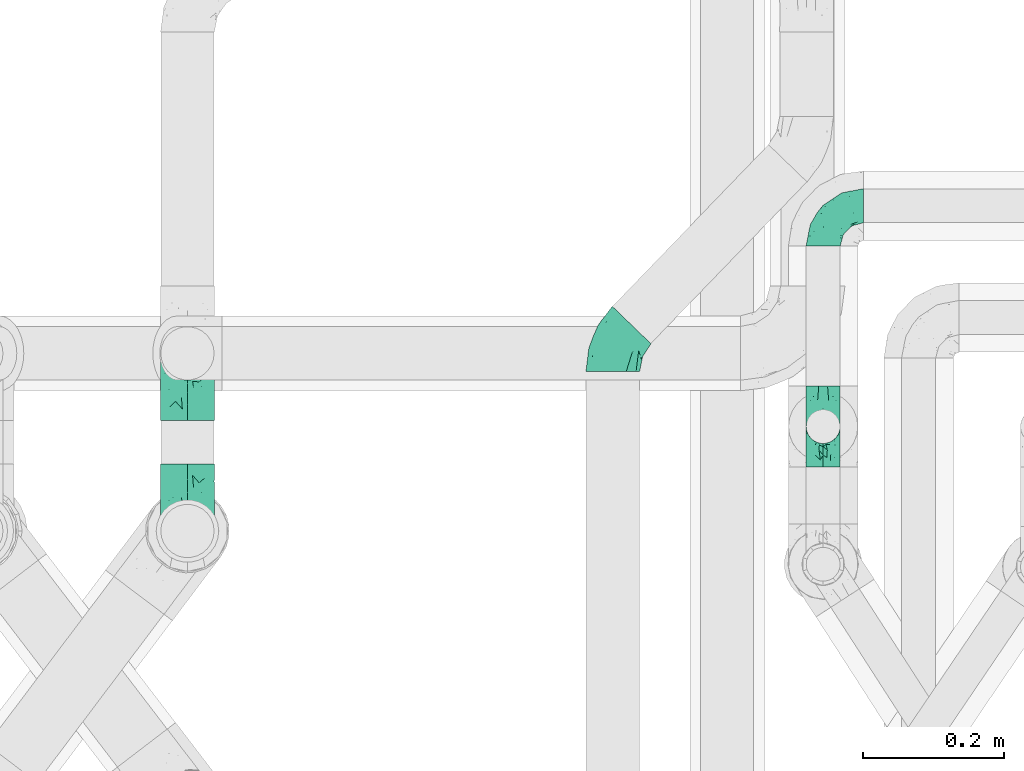
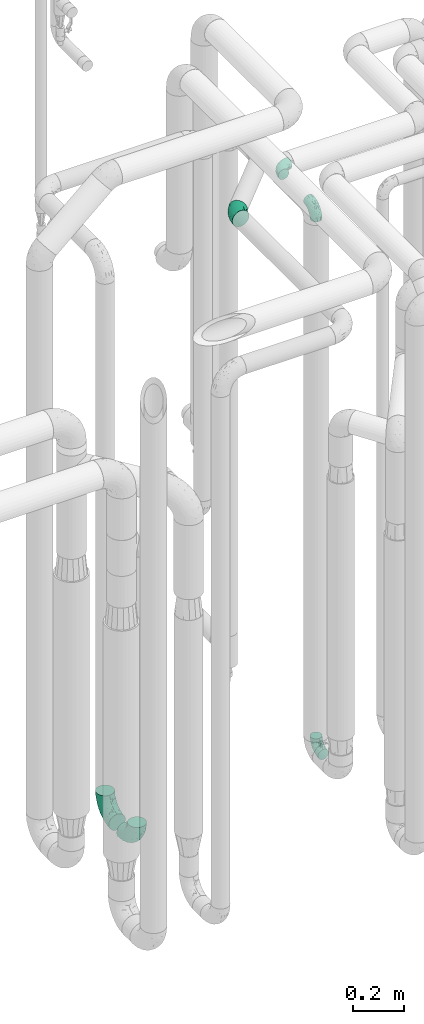
# One storey, part 671 of 827: 6 flow fittings.
"""IFC2X3 building model written with IfcOpenShell, lengths in millimetres."""

import ifcopenshell
import ifcopenshell.guid

model = None  # the IFC model being written
_history = None  # IfcOwnerHistory: only IFC2X3 demands one
_inside = {}  # id of a spatial element -> (the spatial element, [elements in it])
_under = {}  # id of a project, library or spatial element -> (it, [spatial elements below it])
_declared = {}  # id of a project -> (the project, [libraries it declares])
_typed = {}  # id of a type object -> (the type object, [elements of that type])
_made_of = {}  # id of a material, layer set ... -> (it, [elements and type objects made of it])


def new_model(schema):
    """Start an empty IFC model of exactly this schema.

    Asked for "IFC4X3", IfcOpenShell would pick the latest addendum, in which some entities
    have other attributes; the version numbers below select the first issue.
    IFC2X3 requires an IfcOwnerHistory on every rooted entity: one is made here for all.
    """
    global model, _history
    if schema == "IFC4X3":
        model = ifcopenshell.file(schema_version=(4, 3, 0, 0))
    else:
        model = ifcopenshell.file(schema=schema)
    _inside.clear()
    _under.clear()
    _declared.clear()
    _typed.clear()
    _made_of.clear()
    _history = None
    if model.schema == "IFC2X3":
        org = make("IfcOrganization", Name="unknown")
        user = make(
            "IfcPersonAndOrganization",
            ThePerson=make("IfcPerson", FamilyName="unknown"),
            TheOrganization=org,
        )
        app = make(
            "IfcApplication",
            ApplicationDeveloper=org,
            Version="unknown",
            ApplicationFullName="unknown",
            ApplicationIdentifier="unknown",
        )
        _history = make(
            "IfcOwnerHistory",
            OwningUser=user,
            OwningApplication=app,
            ChangeAction="ADDED",
            CreationDate=0,
        )
    return model


def make(cls, **values):
    """One entity of the class cls with the attributes given. An attribute that is None is left unset."""
    return model.create_entity(
        cls, **{name: value for name, value in values.items() if value is not None}
    )


def entity(cls, *values):
    """Any entity or typed value of the class cls, its attributes in the order of the schema. None: left unset."""
    e = model.create_entity(cls)
    for i, value in enumerate(values):
        if value is not None:
            e[i] = value
    return e


def rooted(cls, **values):
    """An entity with a GlobalId (a new one), such as an element, a storey or a relation."""
    return make(cls, GlobalId=ifcopenshell.guid.new(), OwnerHistory=_history, **values)


def si_unit(unit_type, name, prefix=None):
    """IfcSIUnit, for example si_unit("LENGTHUNIT", "METRE", prefix="MILLI")."""
    return make("IfcSIUnit", UnitType=unit_type, Prefix=prefix, Name=name)


def converted_unit(unit_type, name, factor, base, dimensions=None, offset=None):
    """IfcConversionBasedUnit, such as the inch: factor (a typed value) times the base unit."""
    return make(
        "IfcConversionBasedUnit"
        if offset is None
        else "IfcConversionBasedUnitWithOffset",
        ConversionOffset=offset,
        Dimensions=None
        if dimensions is None
        else entity("IfcDimensionalExponents", *dimensions),
        UnitType=unit_type,
        Name=name,
        ConversionFactor=make(
            "IfcMeasureWithUnit", ValueComponent=factor, UnitComponent=base
        ),
    )


def derived_unit(unit_type, elements):
    """IfcDerivedUnit: a product of units, each with its exponent."""
    return make(
        "IfcDerivedUnit",
        Elements=[
            make("IfcDerivedUnitElement", Unit=unit, Exponent=power)
            for unit, power in elements
        ],
        UnitType=unit_type,
    )


def assignment(units):
    """IfcUnitAssignment: the units of a project."""
    return None if units is None else make("IfcUnitAssignment", Units=units)


def point(xyz):
    """IfcCartesianPoint."""
    return None if xyz is None else make("IfcCartesianPoint", Coordinates=xyz)


def direction(xyz):
    """IfcDirection."""
    return None if xyz is None else make("IfcDirection", DirectionRatios=xyz)


def frame(location, z_axis=None, x_axis=None):
    """IfcAxis2Placement3D, a coordinate frame: its origin and axes. An axis left out is left unset."""
    return make(
        "IfcAxis2Placement3D",
        Location=point(location),
        Axis=direction(z_axis),
        RefDirection=direction(x_axis),
    )


def origin():
    """The frame at (0, 0, 0) with its axes left unset."""
    return frame((0.0, 0.0, 0.0))


def place(relative_to, where):
    """IfcLocalPlacement: puts the frame where relative to a parent placement (None: the world)."""
    return make(
        "IfcLocalPlacement", PlacementRelTo=relative_to, RelativePlacement=where
    )


def context(
    kind, dimensions, precision=None, world=None, true_north=None, identifier=None
):
    """IfcGeometricRepresentationContext, for example the 3D "Model" context."""
    return make(
        "IfcGeometricRepresentationContext",
        ContextIdentifier=identifier,
        ContextType=kind,
        CoordinateSpaceDimension=dimensions,
        Precision=precision,
        WorldCoordinateSystem=world,
        TrueNorth=true_north,
    )


def subcontext(parent, identifier, kind, view, scale=None):
    """IfcGeometricRepresentationSubContext, for example "Body" below "Model"."""
    return make(
        "IfcGeometricRepresentationSubContext",
        ContextIdentifier=identifier,
        ContextType=kind,
        ParentContext=parent,
        TargetScale=scale,
        TargetView=view,
    )


def project(units=None, contexts=None):
    """IfcProject with its units and contexts."""
    return rooted(
        "IfcProject",
        Name="project",
        RepresentationContexts=contexts,
        UnitsInContext=assignment(units),
    )


def spatial(cls, under=None, at=None, **own):
    """A site, building, storey or space (cls), placed at a placement, below another one or the project."""
    s = rooted(cls, ObjectPlacement=at, **own)
    if under is not None:
        _under.setdefault(under.id(), (under, []))[1].append(s)
    return s


def faces_of(points, faces, orient=None, outer=None):
    """IfcFace entities. A face is a list of loops; a loop is a list of indices into points, from 0.

    orient and outer hold one flag for each loop. By default every Orientation is true, the
    first loop of a face is its IfcFaceOuterBound and the others are IfcFaceBound.
    """
    made = []
    for i, loops in enumerate(faces):
        bounds = []
        for j, loop in enumerate(loops):
            is_outer = j == 0 if outer is None else outer[i][j]
            bounds.append(
                make(
                    "IfcFaceOuterBound" if is_outer else "IfcFaceBound",
                    Bound=make("IfcPolyLoop", Polygon=[points[k] for k in loop]),
                    Orientation=True if orient is None else orient[i][j],
                )
            )
        made.append(make("IfcFace", Bounds=bounds))
    return made


def faceted_brep(points, faces, orient=None, outer=None, voids=None):
    """IfcFacetedBrep: a solid bounded by flat faces; with voids (closed shells), ...WithVoids."""
    shared = [point(p) for p in points]
    hull = make("IfcClosedShell", CfsFaces=faces_of(shared, faces, orient, outer))
    if voids is None:
        return make("IfcFacetedBrep", Outer=hull)
    return make(
        "IfcFacetedBrepWithVoids",
        Outer=hull,
        Voids=[
            make(cls, CfsFaces=faces_of(shared, fs, o, b)) for cls, fs, o, b in voids
        ],
    )


def shape(context_of_items, identifier, shape_type, items):
    """IfcShapeRepresentation: the items that make up one representation, for example the "Body"."""
    return make(
        "IfcShapeRepresentation",
        ContextOfItems=context_of_items,
        RepresentationIdentifier=identifier,
        RepresentationType=shape_type,
        Items=items,
    )


def source(mapping_origin, context_of_items, identifier, shape_type, items):
    """IfcRepresentationMap: a shape defined once, which mapped items show again and again."""
    return make(
        "IfcRepresentationMap",
        MappingOrigin=mapping_origin,
        MappedRepresentation=shape(context_of_items, identifier, shape_type, items),
    )


def transform(
    local_origin,
    x_axis=None,
    y_axis=None,
    z_axis=None,
    scale=None,
    scale2=None,
    scale3=None,
    uniform=True,
):
    """IfcCartesianTransformationOperator3D, or its non-uniform kind. x_axis, y_axis, z_axis: its Axis1, 2, 3."""
    if uniform:
        return make(
            "IfcCartesianTransformationOperator3D",
            Axis1=direction(x_axis),
            Axis2=direction(y_axis),
            LocalOrigin=point(local_origin),
            Scale=scale,
            Axis3=direction(z_axis),
        )
    return make(
        "IfcCartesianTransformationOperator3DnonUniform",
        Axis1=direction(x_axis),
        Axis2=direction(y_axis),
        LocalOrigin=point(local_origin),
        Scale=scale,
        Axis3=direction(z_axis),
        Scale2=scale2,
        Scale3=scale3,
    )


def mapped(mapping_source, mapping_target):
    """IfcMappedItem: shows the shape of a source again, moved by a transform."""
    return make(
        "IfcMappedItem", MappingSource=mapping_source, MappingTarget=mapping_target
    )


def material(Name=None, Category=None):
    """IfcMaterial."""
    return make("IfcMaterial", Name=Name, Category=Category)


def made_of(thing, what):
    """Note that an element or type object is made of a material, layer set ...; save() writes the relation."""
    if what is not None:
        _made_of.setdefault(what.id(), (what, []))[1].append(thing)
    return thing


def type_object(cls, material=None, **own):
    """A type object (cls), such as IfcWallType, which elements share."""
    return made_of(rooted(cls, **own), material)


def type_shapes(of_type, sources):
    """Give a type object the sources (RepresentationMaps) that its elements show as mapped items."""
    of_type.RepresentationMaps = sources


def element(
    cls,
    number,
    at=None,
    inside=None,
    cuts=None,
    type_object=None,
    material=None,
    context=None,
    identifier="Body",
    shape_type=None,
    held_by="IfcProductDefinitionShape",
    body=None,
    shapes=None,
    **own,
):
    """One element of the class cls, such as IfcWall. Its Tag is "e" and its number.

    at: its placement. inside: the storey or other place that contains it. cuts: it is an
    opening in that element (IfcRelVoidsElement). A single representation is given by context,
    identifier, shape_type and body (its items); several are given by shapes. held_by: the class
    of the entity that holds the representations. save() writes the other relations.
    """
    e = rooted(cls, Tag="e%d" % number, ObjectPlacement=at, **own)
    if body is not None:
        shapes = [shape(context, identifier, shape_type, body)]
    if shapes is not None:
        e.Representation = make(held_by, Representations=shapes)
    if inside is not None:
        _inside.setdefault(inside.id(), (inside, []))[1].append(e)
    if cuts is not None:
        rooted(
            "IfcRelVoidsElement", RelatingBuildingElement=cuts, RelatedOpeningElement=e
        )
    if type_object is not None:
        _typed.setdefault(type_object.id(), (type_object, []))[1].append(e)
    return made_of(e, material)


def aggregate(whole, parts):
    """IfcRelAggregates: a whole, such as a stair, and the parts it consists of."""
    return rooted("IfcRelAggregates", RelatingObject=whole, RelatedObjects=parts)


def save(model, path):
    """Write the relations noted so far, then the file.

    IfcRelAggregates (storeys below a building ...), IfcRelContainedInSpatialStructure (elements
    in a storey), IfcRelDefinesByType, IfcRelAssociatesMaterial and IfcRelDeclares: one each for
    every whole, place, type object, material and project.
    """
    for whole, parts in _under.values():
        aggregate(whole, parts)
    for where, things in _inside.values():
        rooted(
            "IfcRelContainedInSpatialStructure",
            RelatedElements=things,
            RelatingStructure=where,
        )
    for kind, things in _typed.values():
        rooted("IfcRelDefinesByType", RelatedObjects=things, RelatingType=kind)
    for what, things in _made_of.values():
        rooted("IfcRelAssociatesMaterial", RelatedObjects=things, RelatingMaterial=what)
    for by, libraries in _declared.values():
        rooted("IfcRelDeclares", RelatingContext=by, RelatedDefinitions=libraries)
    model.write(path)


model = new_model("IFC2X3")

# Units and contexts
model_context = context("Model", 3, precision=0.01, world=origin(), true_north=direction((6.12303176911189e-17, 1.0)))
body_context = subcontext(model_context, "Body", "Model", "MODEL_VIEW")
ifc_project = project(units=[si_unit("LENGTHUNIT", "METRE", prefix="MILLI"), si_unit("AREAUNIT", "SQUARE_METRE"), si_unit("VOLUMEUNIT", "CUBIC_METRE"), converted_unit("PLANEANGLEUNIT", "DEGREE", entity("IfcRatioMeasure", 0.0174532925199433), si_unit("PLANEANGLEUNIT", "RADIAN"), dimensions=[0, 0, 0, 0, 0, 0, 0]), si_unit("MASSUNIT", "GRAM", prefix="KILO"), derived_unit("MASSDENSITYUNIT", [(si_unit("MASSUNIT", "GRAM", prefix="KILO"), 1), (si_unit("LENGTHUNIT", "METRE"), -3)]), derived_unit("MOMENTOFINERTIAUNIT", [(si_unit("LENGTHUNIT", "METRE"), 4)]), si_unit("TIMEUNIT", "SECOND"), si_unit("FREQUENCYUNIT", "HERTZ"), si_unit("THERMODYNAMICTEMPERATUREUNIT", "DEGREE_CELSIUS"), derived_unit("THERMALTRANSMITTANCEUNIT", [(si_unit("MASSUNIT", "GRAM", prefix="KILO"), 1), (si_unit("THERMODYNAMICTEMPERATUREUNIT", "KELVIN"), -1), (si_unit("TIMEUNIT", "SECOND"), -3)]), derived_unit("VOLUMETRICFLOWRATEUNIT", [(si_unit("LENGTHUNIT", "METRE"), 3), (si_unit("TIMEUNIT", "SECOND"), -1)]), derived_unit("MASSFLOWRATEUNIT", [(si_unit("MASSUNIT", "GRAM", prefix="KILO"), 1), (si_unit("TIMEUNIT", "SECOND"), -1)]), derived_unit("ROTATIONALFREQUENCYUNIT", [(si_unit("TIMEUNIT", "SECOND"), -1)]), si_unit("ELECTRICCURRENTUNIT", "AMPERE"), si_unit("ELECTRICVOLTAGEUNIT", "VOLT"), si_unit("POWERUNIT", "WATT"), si_unit("FORCEUNIT", "NEWTON", prefix="KILO"), si_unit("ILLUMINANCEUNIT", "LUX"), si_unit("LUMINOUSFLUXUNIT", "LUMEN"), si_unit("LUMINOUSINTENSITYUNIT", "CANDELA"), derived_unit("USERDEFINED", [(si_unit("MASSUNIT", "GRAM", prefix="KILO"), -1), (si_unit("LENGTHUNIT", "METRE"), -2), (si_unit("TIMEUNIT", "SECOND"), 3), (si_unit("LUMINOUSFLUXUNIT", "LUMEN"), 1)]), derived_unit("LINEARVELOCITYUNIT", [(si_unit("LENGTHUNIT", "METRE"), 1), (si_unit("TIMEUNIT", "SECOND"), -1)]), si_unit("PRESSUREUNIT", "PASCAL"), derived_unit("USERDEFINED", [(si_unit("LENGTHUNIT", "METRE"), -2), (si_unit("MASSUNIT", "GRAM", prefix="KILO"), 1), (si_unit("TIMEUNIT", "SECOND"), -2)]), derived_unit("LINEARFORCEUNIT", [(si_unit("MASSUNIT", "GRAM", prefix="KILO"), 1), (si_unit("LENGTHUNIT", "METRE"), 1), (si_unit("TIMEUNIT", "SECOND"), -2), (si_unit("LENGTHUNIT", "METRE"), -1)]), derived_unit("PLANARFORCEUNIT", [(si_unit("MASSUNIT", "GRAM", prefix="KILO"), 1), (si_unit("LENGTHUNIT", "METRE"), 1), (si_unit("TIMEUNIT", "SECOND"), -2), (si_unit("LENGTHUNIT", "METRE"), -2)])], contexts=[model_context])

# Site, building, storey
site_placement = place(None, origin())
site = spatial("IfcSite", under=ifc_project, at=site_placement, CompositionType="ELEMENT")
building_placement = place(site_placement, origin())
building = spatial("IfcBuilding", under=site, at=building_placement, CompositionType="ELEMENT")
storey_placement = place(building_placement, frame((0.0, 0.0, 28200.0)))
storey = spatial("IfcBuildingStorey", under=building, at=storey_placement, Name="08", CompositionType="ELEMENT", Elevation=28200.0)

# Flow fittings
ifc_material = material()
pipe_fitting_type_1 = type_object("IfcPipeFittingType", Name="ADSK_1", PredefinedType="NOTDEFINED", material=ifc_material)
shared_shape_1 = source(origin(), body_context, "Body", "Brep", [
    faceted_brep([(-57.0, 12.07, -20.91), (-57.0, 6.25, -23.33), (-57.0, 0.0, -24.15), (-57.0, -6.25, -23.33), (-57.0, -12.08, -20.91), (-57.0, -17.08, -17.08), (-57.0, -20.91, -12.08), (-57.0, -23.33, -6.25), (-57.0, -24.15, 0.0), (-57.0, -23.33, 6.25), (-57.0, -20.91, 12.07), (-57.0, -17.08, 17.08), (-57.0, -12.08, 20.91), (-57.0, -6.25, 23.33), (-57.0, 0.0, 24.15), (-57.0, 6.25, 23.33), (-57.0, 12.07, 20.91), (-57.0, 17.08, 17.08), (-57.0, 20.91, 12.07), (-57.0, 23.33, 6.25), (-57.0, 24.15, 0.0), (-57.0, 23.33, -6.25), (-57.0, 20.91, -12.08), (-57.0, 17.08, -17.08), (0.0, 57.0, -24.15), (-6.25, 57.0, -23.33), (-12.07, 57.0, -20.91), (-17.08, 57.0, -17.08), (-20.91, 57.0, -12.08), (-23.33, 57.0, -6.25), (-24.15, 57.0, 0.0), (-23.33, 57.0, 6.25), (-20.91, 57.0, 12.07), (-17.08, 57.0, 17.08), (-12.07, 57.0, 20.91), (-6.25, 57.0, 23.33), (0.0, 57.0, 24.15), (6.25, 57.0, 23.33), (12.08, 57.0, 20.91), (17.08, 57.0, 17.08), (20.91, 57.0, 12.07), (23.33, 57.0, 6.25), (24.15, 57.0, 0.0), (23.33, 57.0, -6.25), (20.91, 57.0, -12.08), (17.08, 57.0, -17.08), (12.08, 57.0, -20.91), (6.25, 57.0, -23.33), (14.9, 21.14, 6.17), (13.61, 24.64, 12.48), (6.23, 8.95, 8.98), (-41.47, -21.06, 0.0), (-41.92, -18.38, 13.72), (-24.64, -13.61, 12.48), (-37.37, -13.24, 18.15), (-6.8, -4.93, 8.18), (-21.76, -15.19, 6.22), (-12.78, -9.18, 0.0), (-37.73, -20.51, 7.75), (-7.38, 7.38, 20.24), (-23.37, -4.26, 20.42), (-11.9, -3.19, 15.86), (-42.14, -8.7, 21.82), (13.24, 37.37, 18.15), (9.33, 23.53, 16.85), (4.26, 23.37, 20.42), (2.77, 10.92, 15.55), (-29.46, 0.91, 23.52), (-44.13, 20.56, 15.69), (-39.25, 26.33, 10.88), (-49.02, 22.92, 9.96), (-34.58, 23.87, 17.15), (-15.8, 6.8, 22.81), (-8.67, 20.47, 23.88), (-18.12, 12.9, 24.08), (-48.29, 14.92, 19.65), (-44.06, -2.85, 23.78), (-9.23, 48.95, 22.58), (-3.78, 42.74, 24.07), (-40.34, 4.26, 24.09), (-44.02, 26.14, 5.46), (-44.04, 9.88, 22.74), (-4.95, 16.87, 22.52), (-2.75, 1.43, 12.5), (-25.48, 40.98, 10.71), (20.51, 37.73, 7.75), (18.38, 41.92, 13.72), (8.7, 42.14, 21.82), (-25.95, -17.97, 0.0), (2.85, 44.06, 23.78), (21.06, 41.47, 0.0), (17.97, 25.95, 0.0), (-24.04, -9.27, 17.13), (-33.26, 33.26, 5.86), (-28.55, 40.57, 0.0), (-40.57, 28.55, 0.0), (-25.29, 47.19, 4.06), (-27.01, 31.1, 16.77), (-15.7, 43.95, 19.9), (-20.27, 45.22, 15.61), (-30.53, 31.98, 12.64), (-11.28, 38.33, 22.92), (-9.97, 27.88, 24.09), (-20.15, 30.26, 21.25), (-31.25, 11.75, 23.64), (-28.75, 7.23, 24.15), (-29.53, 18.06, 22.27), (-28.44, 24.21, 20.02), (-37.55, 17.7, 20.26), (-15.88, 29.25, 22.99), (-20.82, 20.82, 23.44), (-0.91, 29.46, 23.52), (-13.5, -7.67, 12.04), (1.49, 1.56, 5.16), (8.86, 10.35, 4.59), (0.38, -0.38, 0.0), (9.18, 12.78, 0.0), (-37.37, -13.24, -18.15), (8.86, 10.35, -4.59), (-45.22, 20.27, -15.61), (-43.95, 15.7, -19.9), (-38.33, 11.28, -22.92), (-48.95, 9.23, -22.58), (-47.19, 25.29, -4.06), (-33.26, 33.26, -5.86), (18.38, 41.92, -13.72), (-30.26, 20.15, -21.25), (2.85, 44.06, -23.78), (-4.26, 40.34, -24.09), (-40.98, 25.48, -10.71), (-41.92, -18.38, -13.72), (9.25, 23.5, -16.92), (4.26, 23.37, -20.42), (13.24, 37.37, -18.15), (-37.73, -20.51, -7.75), (-11.75, 31.25, -23.64), (-7.23, 28.75, -24.15), (-12.9, 18.12, -24.08), (8.7, 42.14, -21.82), (-44.06, -2.85, -23.78), (-6.8, 15.8, -22.81), (-20.47, 8.67, -23.88), (-24.64, -13.61, -12.48), (-42.74, 3.78, -24.07), (-18.06, 29.53, -22.27), (-24.21, 28.44, -20.02), (-27.88, 9.97, -24.09), (-31.1, 27.01, -16.77), (-26.14, 44.02, -5.46), (14.9, 21.14, -6.17), (20.51, 37.73, -7.75), (-9.88, 44.04, -22.74), (-20.56, 44.13, -15.69), (-21.76, -15.19, -6.22), (-13.5, -7.67, -12.04), (-24.14, -9.76, -16.74), (-11.9, -3.19, -15.86), (-14.92, 48.29, -19.65), (-23.37, -4.26, -20.42), (-0.91, 29.46, -23.52), (-26.33, 39.25, -10.88), (-23.87, 34.58, -17.15), (-42.14, -8.7, -21.82), (-22.92, 49.02, -9.96), (13.61, 24.64, -12.48), (-31.98, 30.53, -12.64), (-16.87, 4.95, -22.52), (-17.7, 37.55, -20.26), (-29.25, 15.88, -22.99), (-20.82, 20.82, -23.44), (-29.46, 0.91, -23.52), (-7.38, 7.38, -20.24), (2.77, 10.92, -15.55), (6.23, 8.95, -8.98), (-6.8, -4.93, -8.18), (-2.81, 1.41, -12.54), (1.49, 1.56, -5.16)], [[[0, 1, 2, 3, 4, 5, 6, 7, 8, 9, 10, 11, 12, 13, 14, 15, 16, 17, 18, 19, 20, 21, 22, 23]], [[24, 25, 26, 27, 28, 29, 30, 31, 32, 33, 34, 35, 36, 37, 38, 39, 40, 41, 42, 43, 44, 45, 46, 47]], [[48, 49, 50]], [[9, 8, 51]], [[52, 53, 54]], [[55, 56, 57]], [[10, 58, 52]], [[9, 58, 10]], [[59, 60, 61]], [[54, 12, 11]], [[54, 62, 12]], [[63, 39, 38]], [[64, 65, 66]], [[62, 60, 67]], [[68, 69, 70]], [[71, 69, 68]], [[72, 73, 74]], [[16, 75, 17]], [[13, 76, 14]], [[35, 77, 78]], [[14, 79, 15]], [[17, 68, 18]], [[14, 76, 79]], [[20, 19, 80]], [[70, 19, 18]], [[81, 15, 79]], [[15, 81, 16]], [[73, 72, 82]], [[66, 83, 50]], [[32, 31, 84]], [[85, 86, 49]], [[63, 87, 65]], [[56, 58, 88]], [[36, 89, 37]], [[85, 41, 40]], [[36, 35, 78]], [[90, 41, 85]], [[40, 39, 86]], [[12, 62, 13]], [[86, 85, 40]], [[48, 85, 49]], [[85, 91, 90]], [[87, 38, 37]], [[92, 60, 54]], [[80, 69, 93]], [[93, 94, 95]], [[10, 52, 11]], [[94, 96, 30]], [[97, 98, 99]], [[80, 93, 95]], [[100, 97, 84]], [[99, 98, 33]], [[101, 102, 78]], [[103, 101, 98]], [[96, 31, 30]], [[77, 98, 101]], [[77, 35, 34]], [[34, 33, 98]], [[9, 51, 58]], [[87, 63, 38]], [[104, 105, 74]], [[106, 103, 107]], [[106, 81, 104]], [[75, 68, 17]], [[108, 107, 71]], [[33, 32, 99]], [[109, 103, 110]], [[101, 109, 102]], [[89, 78, 111]], [[53, 52, 58]], [[54, 11, 52]], [[60, 62, 54]], [[88, 58, 51]], [[76, 62, 67]], [[53, 112, 92]], [[60, 59, 72]], [[39, 63, 86]], [[49, 86, 63]], [[89, 87, 37]], [[42, 41, 90]], [[111, 82, 65]], [[111, 65, 87]], [[65, 59, 66]], [[104, 81, 79]], [[75, 81, 108]], [[32, 84, 99]], [[97, 99, 84]], [[98, 97, 103]], [[106, 107, 108]], [[74, 102, 110]], [[111, 78, 102]], [[74, 110, 104]], [[74, 67, 72]], [[61, 92, 112]], [[66, 59, 61]], [[56, 53, 58]], [[66, 50, 49]], [[61, 112, 83]], [[66, 49, 64]], [[78, 89, 36]], [[87, 89, 111]], [[62, 76, 13]], [[79, 76, 67]], [[100, 93, 69]], [[96, 93, 84]], [[55, 113, 50]], [[113, 114, 50]], [[104, 79, 105]], [[106, 104, 110]], [[20, 80, 95]], [[85, 48, 91]], [[115, 114, 113]], [[116, 91, 48]], [[70, 80, 19]], [[93, 96, 94]], [[84, 31, 96]], [[103, 106, 110]], [[81, 106, 108]], [[103, 97, 107]], [[71, 107, 97]], [[71, 97, 100]], [[108, 71, 68]], [[79, 67, 105]], [[67, 74, 105]], [[115, 113, 57]], [[112, 56, 55]], [[56, 88, 57]], [[60, 72, 67]], [[82, 72, 59]], [[65, 82, 59]], [[82, 111, 73]], [[111, 102, 73]], [[102, 74, 73]], [[81, 75, 16]], [[68, 75, 108]], [[68, 70, 18]], [[80, 70, 69]], [[98, 77, 34]], [[78, 77, 101]], [[93, 100, 84]], [[71, 100, 69]], [[102, 109, 110]], [[101, 103, 109]], [[53, 92, 54]], [[61, 60, 92]], [[56, 112, 53]], [[83, 112, 55]], [[50, 83, 55]], [[61, 83, 66]], [[49, 63, 64]], [[65, 64, 63]], [[57, 113, 55]], [[114, 115, 116]], [[116, 48, 114]], [[48, 50, 114]], [[117, 5, 4]], [[116, 115, 118]], [[119, 120, 23]], [[121, 122, 120]], [[95, 123, 20]], [[0, 23, 120]], [[124, 95, 94]], [[125, 45, 44]], [[121, 120, 126]], [[24, 127, 128]], [[22, 21, 129]], [[0, 122, 1]], [[5, 117, 130]], [[131, 132, 133]], [[134, 88, 51]], [[135, 136, 137]], [[6, 5, 130]], [[46, 138, 47]], [[139, 3, 2]], [[140, 141, 137]], [[6, 134, 7]], [[134, 130, 142]], [[143, 2, 1]], [[144, 126, 145]], [[121, 146, 143]], [[147, 120, 119]], [[94, 148, 124]], [[149, 150, 91]], [[30, 29, 148]], [[151, 25, 128]], [[27, 152, 28]], [[134, 153, 88]], [[154, 155, 156]], [[27, 26, 157]], [[151, 26, 25]], [[155, 158, 156]], [[24, 47, 127]], [[1, 122, 143]], [[138, 132, 159]], [[160, 152, 161]], [[24, 128, 25]], [[46, 133, 138]], [[162, 117, 4]], [[148, 160, 124]], [[152, 160, 163]], [[154, 142, 155]], [[45, 125, 133]], [[133, 46, 45]], [[125, 164, 133]], [[51, 7, 134]], [[42, 90, 43]], [[165, 147, 129]], [[153, 134, 142]], [[43, 150, 44]], [[162, 4, 3]], [[141, 140, 166]], [[117, 162, 158]], [[163, 29, 28]], [[43, 90, 150]], [[123, 21, 20]], [[144, 151, 135]], [[157, 152, 27]], [[167, 145, 161]], [[23, 22, 119]], [[168, 126, 169]], [[121, 168, 146]], [[139, 143, 170]], [[142, 130, 117]], [[8, 7, 51]], [[134, 6, 130]], [[139, 162, 3]], [[170, 166, 158]], [[170, 158, 162]], [[158, 171, 156]], [[44, 150, 125]], [[91, 150, 90]], [[164, 125, 150]], [[132, 138, 133]], [[127, 138, 159]], [[131, 164, 172]], [[132, 171, 140]], [[135, 151, 128]], [[157, 151, 167]], [[22, 129, 119]], [[147, 119, 129]], [[120, 147, 126]], [[144, 145, 167]], [[137, 146, 169]], [[170, 143, 146]], [[137, 169, 135]], [[137, 159, 140]], [[171, 172, 156]], [[173, 174, 175]], [[156, 175, 154]], [[174, 57, 153]], [[132, 172, 171]], [[172, 164, 173]], [[143, 139, 2]], [[162, 139, 170]], [[138, 127, 47]], [[128, 127, 159]], [[165, 124, 160]], [[123, 124, 129]], [[149, 173, 164]], [[176, 174, 173]], [[135, 128, 136]], [[144, 135, 169]], [[150, 149, 164]], [[176, 118, 115]], [[149, 91, 116]], [[30, 148, 94]], [[163, 148, 29]], [[124, 123, 95]], [[129, 21, 123]], [[126, 144, 169]], [[151, 144, 167]], [[126, 147, 145]], [[161, 145, 147]], [[161, 147, 165]], [[167, 161, 152]], [[128, 159, 136]], [[159, 137, 136]], [[154, 153, 142]], [[132, 140, 159]], [[174, 176, 57]], [[57, 88, 153]], [[166, 140, 171]], [[158, 166, 171]], [[166, 170, 141]], [[170, 146, 141]], [[146, 137, 141]], [[151, 157, 26]], [[152, 157, 167]], [[152, 163, 28]], [[148, 163, 160]], [[120, 122, 0]], [[143, 122, 121]], [[124, 165, 129]], [[161, 165, 160]], [[146, 168, 169]], [[121, 126, 168]], [[142, 117, 155]], [[158, 155, 117]], [[175, 156, 172]], [[153, 154, 174]], [[173, 175, 172]], [[174, 154, 175]], [[164, 131, 133]], [[172, 132, 131]], [[176, 173, 118]], [[57, 176, 115]], [[173, 149, 118]], [[149, 116, 118]]]),
])
type_shapes(pipe_fitting_type_1, [shared_shape_1])
for number, where, z_axis, x_axis, name in (
    (1, (46692.79, 14434.53, 400.0), (-1.0, 0.0, 0.0), (0.0, 0.0, -1.0), "ADSK_1"),
    (2, (46692.79, 14434.53, 3000.0), (-1.0, 0.0, 0.0), (0.0, 0.0, 1.0), "ADSK_1"),
    (3, (46692.79, 14747.03, 3000.0), (0.0, 0.0, 1.0), (-1.0, 0.0, 0.0), "ADSK_1"),
):
    element("IfcFlowFitting", number, at=place(storey_placement, frame(where, z_axis=z_axis, x_axis=x_axis)), inside=storey, type_object=pipe_fitting_type_1, material=ifc_material, Name=name, ObjectType="ADSK_1", context=body_context, shape_type="MappedRepresentation", body=[
        mapped(shared_shape_1, transform((0.0, 0.0, 0.0), scale=1.0)),
    ])
pipe_fitting_type_2 = type_object("IfcPipeFittingType", Name="ADSK_1", PredefinedType="NOTDEFINED", material=ifc_material)
shared_shape_2 = source(origin(), body_context, "Body", "Brep", [
    faceted_brep([(-95.0, 19.02, -32.95), (-95.0, 9.85, -36.75), (-95.0, 0.0, -38.05), (-95.0, -9.85, -36.75), (-95.0, -19.03, -32.95), (-95.0, -26.91, -26.91), (-95.0, -32.95, -19.03), (-95.0, -36.75, -9.85), (-95.0, -38.05, 0.0), (-95.0, -36.75, 9.85), (-95.0, -32.95, 19.02), (-95.0, -26.91, 26.91), (-95.0, -19.03, 32.95), (-95.0, -9.85, 36.75), (-95.0, 0.0, 38.05), (-95.0, 9.85, 36.75), (-95.0, 19.02, 32.95), (-95.0, 26.91, 26.91), (-95.0, 32.95, 19.02), (-95.0, 36.75, 9.85), (-95.0, 38.05, 0.0), (-95.0, 36.75, -9.85), (-95.0, 32.95, -19.03), (-95.0, 26.91, -26.91), (0.0, 95.0, -38.05), (-9.85, 95.0, -36.75), (-19.02, 95.0, -32.95), (-26.91, 95.0, -26.91), (-32.95, 95.0, -19.03), (-36.75, 95.0, -9.85), (-38.05, 95.0, 0.0), (-36.75, 95.0, 9.85), (-32.95, 95.0, 19.02), (-26.91, 95.0, 26.91), (-19.02, 95.0, 32.95), (-9.85, 95.0, 36.75), (0.0, 95.0, 38.05), (9.85, 95.0, 36.75), (19.03, 95.0, 32.95), (26.91, 95.0, 26.91), (32.95, 95.0, 19.02), (36.75, 95.0, 9.85), (38.05, 95.0, 0.0), (36.75, 95.0, -9.85), (32.95, 95.0, -19.03), (26.91, 95.0, -26.91), (19.03, 95.0, -32.95), (9.85, 95.0, -36.75), (-7.99, -4.96, 6.3), (-0.92, 0.92, 0.0), (4.62, 8.1, 8.01), (-76.19, -35.57, 0.0), (-64.32, -32.32, 12.43), (20.51, 62.45, 28.68), (-60.56, -33.52, 0.0), (-70.4, -13.47, 34.42), (-39.61, -5.88, 32.32), (-49.6, 2.07, 37.1), (-70.34, -28.81, 21.71), (14.64, 40.81, 26.5), (5.88, 39.61, 32.32), (3.59, 20.77, 25.31), (-40.45, 68.06, 16.75), (-62.45, -20.51, 28.68), (-44.52, -26.87, 0.0), (-28.47, -20.22, 0.0), (-26.43, -17.83, 8.75), (-76.1, 39.63, 10.76), (-72.74, 37.58, 18.19), (-60.35, 46.18, 14.61), (-13.4, 13.4, 32.12), (-20.77, -3.59, 25.31), (-14.66, 81.47, 35.56), (-6.22, 71.26, 37.92), (-57.5, 42.48, 22.79), (-15.0, 34.74, 37.7), (-27.1, 12.08, 36.05), (-9.2, 28.81, 35.63), (-79.98, 23.7, 30.95), (-73.68, -4.3, 37.48), (-30.74, 21.67, 37.97), (-62.36, 47.59, 6.79), (-72.71, 32.83, 24.69), (-67.42, 7.02, 37.95), (-32.13, 75.27, 24.51), (-43.46, 51.47, 26.26), (-24.98, 73.15, 31.29), (20.59, 41.28, 19.85), (7.79, 16.09, 15.86), (-73.21, 42.39, 0.0), (-54.73, 54.73, 0.0), (-73.44, 15.79, 35.79), (-5.94, 4.32, 20.43), (28.81, 70.34, 21.71), (32.32, 64.32, 12.43), (-53.59, 26.2, 35.09), (-52.02, 19.31, 37.21), (21.38, 33.53, 10.34), (26.87, 44.52, 0.0), (-48.28, 12.14, 38.05), (4.3, 73.68, 37.48), (-44.08, -25.52, 12.79), (-41.28, -20.59, 19.85), (35.57, 76.19, 0.0), (-47.26, 54.3, 20.18), (-47.4, 61.99, 8.58), (-42.39, 73.21, 0.0), (-39.67, 78.86, 7.21), (-45.69, 36.84, 33.11), (-32.83, 50.13, 33.35), (13.47, 70.4, 34.42), (-18.25, 63.73, 36.07), (-40.63, -13.75, 27.22), (-16.63, 46.37, 37.95), (-53.47, 38.79, 28.59), (-26.07, 48.54, 36.15), (-34.51, 34.51, 36.86), (-2.07, 49.6, 37.1), (-22.79, -10.49, 19.23), (-61.73, 28.67, 31.87), (9.65, 14.7, 0.0), (20.22, 28.47, 0.0), (33.52, 60.56, 0.0), (-11.42, -5.44, 13.25), (-14.7, -9.65, 0.0), (-81.47, 14.66, -35.56), (-62.45, -20.51, -28.68), (-71.26, 6.22, -37.92), (-75.27, 32.13, -24.51), (-73.15, 24.98, -31.29), (13.47, 70.4, -34.42), (5.88, 39.61, -32.32), (-2.07, 49.6, -37.1), (-78.86, 39.67, -7.21), (-70.4, -13.47, -34.42), (-39.61, -5.88, -32.32), (-61.99, 47.4, -8.58), (32.32, 64.32, -12.43), (28.81, 70.34, -21.71), (-63.73, 18.25, -36.07), (-50.13, 32.83, -33.35), (4.3, 73.68, -37.48), (-7.02, 67.42, -37.95), (-39.63, 76.1, -10.76), (-46.18, 60.35, -14.61), (-47.59, 62.36, -6.79), (-64.32, -32.32, -12.43), (-26.2, 53.59, -35.09), (-15.79, 73.44, -35.79), (-19.31, 52.02, -37.21), (-37.58, 72.74, -18.19), (-70.34, -28.81, -21.71), (-42.48, 57.5, -22.79), (-38.79, 53.47, -28.59), (-51.47, 43.46, -26.26), (-32.83, 72.71, -24.69), (-46.37, 16.63, -37.95), (-73.68, -4.3, -37.48), (-41.28, -20.59, -19.85), (-44.08, -25.52, -12.79), (13.75, 40.63, -27.22), (20.51, 62.45, -28.68), (-68.06, 40.45, -16.75), (-54.3, 47.26, -20.18), (-12.14, 48.28, -38.05), (-21.67, 30.74, -37.97), (-36.84, 45.69, -33.11), (-11.42, -5.44, -13.25), (7.79, 16.09, -15.86), (4.62, 8.1, -8.01), (-23.7, 79.98, -30.95), (-26.43, -17.83, -8.75), (-7.99, -4.96, -6.3), (-40.81, -14.64, -26.5), (-20.77, -3.59, -25.31), (-34.74, 15.0, -37.7), (-12.08, 27.1, -36.05), (-28.81, 9.2, -35.63), (-22.79, -10.49, -19.23), (21.38, 33.53, -10.34), (20.59, 41.28, -19.85), (-48.54, 26.07, -36.15), (-49.6, 2.07, -37.1), (-13.4, 13.4, -32.12), (3.59, 20.77, -25.31), (-28.67, 61.73, -31.87), (-34.51, 34.51, -36.86), (-5.94, 4.32, -20.43)], [[[0, 1, 2, 3, 4, 5, 6, 7, 8, 9, 10, 11, 12, 13, 14, 15, 16, 17, 18, 19, 20, 21, 22, 23]], [[24, 25, 26, 27, 28, 29, 30, 31, 32, 33, 34, 35, 36, 37, 38, 39, 40, 41, 42, 43, 44, 45, 46, 47]], [[48, 49, 50]], [[51, 52, 9]], [[53, 39, 38]], [[9, 52, 10]], [[54, 52, 51]], [[55, 56, 57]], [[11, 10, 58]], [[59, 60, 61]], [[32, 31, 62]], [[63, 12, 11]], [[63, 55, 12]], [[64, 65, 66]], [[67, 68, 69]], [[70, 56, 71]], [[35, 72, 73]], [[69, 68, 74]], [[75, 76, 77]], [[16, 78, 17]], [[13, 79, 14]], [[76, 75, 80]], [[67, 69, 81]], [[18, 17, 82]], [[14, 79, 83]], [[20, 19, 67]], [[84, 85, 86]], [[87, 61, 88]], [[89, 81, 90]], [[18, 82, 68]], [[15, 91, 16]], [[14, 83, 15]], [[71, 92, 61]], [[17, 78, 82]], [[93, 87, 94]], [[95, 91, 96]], [[97, 98, 94]], [[86, 72, 34]], [[96, 99, 80]], [[37, 36, 100]], [[40, 39, 93]], [[40, 94, 41]], [[64, 66, 101]], [[93, 94, 40]], [[58, 102, 63]], [[94, 103, 41]], [[94, 87, 97]], [[104, 69, 74]], [[34, 33, 86]], [[105, 69, 104]], [[52, 58, 10]], [[106, 107, 30]], [[108, 109, 85]], [[105, 106, 90]], [[53, 110, 60]], [[86, 111, 72]], [[86, 109, 111]], [[33, 84, 86]], [[12, 55, 13]], [[112, 56, 63]], [[110, 38, 37]], [[34, 72, 35]], [[36, 35, 73]], [[111, 113, 73]], [[105, 107, 106]], [[110, 53, 38]], [[74, 114, 85]], [[91, 15, 83]], [[105, 90, 81]], [[107, 62, 31]], [[33, 32, 84]], [[115, 109, 116]], [[111, 115, 113]], [[100, 73, 117]], [[56, 55, 63]], [[79, 55, 57]], [[102, 118, 112]], [[56, 70, 76]], [[100, 110, 37]], [[117, 77, 60]], [[117, 60, 110]], [[60, 70, 61]], [[58, 52, 101]], [[63, 11, 58]], [[39, 53, 93]], [[87, 93, 53]], [[96, 91, 83]], [[78, 91, 119]], [[32, 62, 84]], [[84, 62, 104]], [[86, 85, 109]], [[85, 114, 108]], [[80, 113, 116]], [[117, 73, 113]], [[80, 116, 96]], [[80, 57, 76]], [[71, 112, 118]], [[61, 87, 59]], [[62, 107, 105]], [[97, 120, 121]], [[70, 71, 61]], [[71, 118, 92]], [[73, 100, 36]], [[110, 100, 117]], [[55, 79, 13]], [[83, 79, 57]], [[96, 83, 99]], [[116, 108, 95]], [[50, 97, 88]], [[97, 87, 88]], [[50, 49, 120]], [[122, 94, 98]], [[89, 20, 67]], [[105, 81, 69]], [[89, 67, 81]], [[68, 19, 18]], [[68, 67, 19]], [[74, 68, 82]], [[114, 82, 119]], [[74, 85, 104]], [[82, 114, 74]], [[114, 119, 108]], [[95, 108, 119]], [[116, 109, 108]], [[123, 48, 50]], [[97, 50, 120]], [[123, 50, 88]], [[91, 95, 119]], [[116, 95, 96]], [[84, 104, 85]], [[104, 62, 105]], [[83, 57, 99]], [[57, 80, 99]], [[66, 48, 123]], [[66, 124, 48]], [[118, 66, 123]], [[124, 66, 65]], [[66, 118, 101]], [[54, 64, 52]], [[124, 49, 48]], [[30, 107, 31]], [[91, 78, 16]], [[82, 78, 119]], [[56, 76, 57]], [[77, 76, 70]], [[60, 77, 70]], [[77, 117, 75]], [[117, 113, 75]], [[113, 80, 75]], [[9, 8, 51]], [[103, 94, 122]], [[103, 42, 41]], [[73, 72, 111]], [[113, 115, 116]], [[111, 109, 115]], [[102, 112, 63]], [[71, 56, 112]], [[118, 102, 101]], [[92, 123, 88]], [[123, 92, 118]], [[61, 92, 88]], [[87, 53, 59]], [[60, 59, 53]], [[97, 121, 98]], [[58, 101, 102]], [[64, 101, 52]], [[125, 1, 0]], [[126, 5, 4]], [[2, 1, 127]], [[1, 125, 127]], [[128, 129, 23]], [[130, 131, 132]], [[89, 133, 20]], [[126, 134, 135]], [[136, 89, 90]], [[137, 138, 44]], [[139, 129, 140]], [[24, 141, 142]], [[143, 144, 145]], [[125, 129, 139]], [[6, 146, 7]], [[147, 148, 149]], [[146, 51, 7]], [[143, 150, 144]], [[146, 6, 151]], [[152, 153, 154]], [[126, 4, 134]], [[0, 23, 129]], [[28, 155, 150]], [[43, 42, 103]], [[54, 146, 64]], [[139, 156, 127]], [[157, 3, 2]], [[151, 158, 159]], [[160, 131, 161]], [[22, 21, 162]], [[136, 144, 163]], [[149, 164, 165]], [[24, 142, 25]], [[166, 140, 154]], [[154, 129, 128]], [[143, 30, 29]], [[167, 168, 169]], [[155, 28, 27]], [[26, 170, 27]], [[171, 167, 172]], [[26, 25, 148]], [[27, 170, 155]], [[173, 135, 174]], [[144, 150, 152]], [[175, 176, 177]], [[24, 47, 141]], [[45, 161, 46]], [[148, 25, 142]], [[176, 175, 165]], [[64, 159, 171]], [[138, 45, 44]], [[130, 46, 161]], [[137, 44, 43]], [[178, 159, 158]], [[137, 103, 122]], [[163, 144, 152]], [[136, 133, 89]], [[103, 137, 43]], [[6, 5, 151]], [[178, 158, 173]], [[134, 4, 3]], [[178, 173, 174]], [[137, 98, 179]], [[145, 90, 106]], [[138, 180, 161]], [[46, 130, 47]], [[136, 90, 145]], [[133, 162, 21]], [[23, 22, 128]], [[139, 140, 181]], [[139, 181, 156]], [[157, 127, 182]], [[157, 134, 3]], [[182, 177, 135]], [[182, 135, 134]], [[135, 183, 174]], [[131, 130, 161]], [[141, 130, 132]], [[160, 180, 184]], [[131, 183, 176]], [[5, 126, 151]], [[158, 151, 126]], [[180, 138, 137]], [[161, 45, 138]], [[149, 148, 142]], [[170, 148, 185]], [[22, 162, 128]], [[128, 162, 163]], [[129, 154, 140]], [[154, 153, 166]], [[165, 156, 186]], [[182, 127, 156]], [[165, 186, 149]], [[165, 132, 176]], [[131, 184, 183]], [[187, 167, 178]], [[184, 168, 187]], [[167, 169, 172]], [[184, 180, 168]], [[174, 183, 184]], [[127, 157, 2]], [[134, 157, 182]], [[130, 141, 47]], [[142, 141, 132]], [[149, 142, 164]], [[186, 166, 147]], [[180, 179, 168]], [[169, 179, 120]], [[137, 179, 180]], [[179, 121, 120]], [[106, 30, 143]], [[136, 145, 144]], [[106, 143, 145]], [[150, 29, 28]], [[150, 143, 29]], [[152, 150, 155]], [[153, 155, 185]], [[152, 154, 163]], [[155, 153, 152]], [[153, 185, 166]], [[147, 166, 185]], [[186, 140, 166]], [[169, 120, 49]], [[169, 49, 172]], [[179, 169, 168]], [[148, 147, 185]], [[186, 147, 149]], [[128, 163, 154]], [[163, 162, 136]], [[142, 132, 164]], [[132, 165, 164]], [[171, 124, 65]], [[124, 171, 172]], [[64, 146, 159]], [[171, 159, 178]], [[171, 65, 64]], [[172, 49, 124]], [[162, 133, 136]], [[20, 133, 21]], [[148, 170, 26]], [[155, 170, 185]], [[131, 176, 132]], [[177, 176, 183]], [[135, 177, 183]], [[177, 182, 175]], [[182, 156, 175]], [[156, 165, 175]], [[51, 146, 54]], [[51, 8, 7]], [[129, 125, 0]], [[127, 125, 139]], [[140, 186, 181]], [[156, 181, 186]], [[158, 126, 173]], [[135, 173, 126]], [[187, 178, 174]], [[171, 178, 167]], [[184, 187, 174]], [[167, 187, 168]], [[180, 160, 161]], [[184, 131, 160]], [[98, 137, 122]], [[98, 121, 179]], [[151, 159, 146]]]),
])
type_shapes(pipe_fitting_type_2, [shared_shape_2])
for number, where, z_axis, x_axis, name in (
    (4, (45793.07, 14538.08, 350.0), (-1.0, 0.0, 0.0), (0.0, 0.0, -1.0), "ADSK_1"),
    (5, (45793.07, 14286.62, 350.0), (-1.0, 0.0, 0.0), (0.0, -1.0, 0.0), "ADSK_1"),
):
    element("IfcFlowFitting", number, at=place(storey_placement, frame(where, z_axis=z_axis, x_axis=x_axis)), inside=storey, type_object=pipe_fitting_type_2, material=ifc_material, Name=name, ObjectType="ADSK_1", context=body_context, shape_type="MappedRepresentation", body=[
        mapped(shared_shape_2, transform((0.0, 0.0, 0.0), scale=1.0)),
    ])
pipe_fitting_type_3 = type_object("IfcPipeFittingType", Name="ADSK_1", PredefinedType="NOTDEFINED", material=ifc_material)
shared_shape_3 = source(origin(), body_context, "Body", "Brep", [
    faceted_brep([(-38.38, 19.02, -32.95), (-38.38, 9.85, -36.75), (-38.38, 0.0, -38.05), (-38.38, -9.85, -36.75), (-38.38, -19.03, -32.95), (-38.38, -26.91, -26.91), (-38.38, -32.95, -19.03), (-38.38, -36.75, -9.85), (-38.38, -38.05, 0.0), (-38.38, -36.75, 9.85), (-38.38, -32.95, 19.02), (-38.38, -26.91, 26.91), (-38.38, -19.03, 32.95), (-38.38, -9.85, 36.75), (-38.38, 0.0, 38.05), (-38.38, 9.85, 36.75), (-38.38, 19.02, 32.95), (-38.38, 26.91, 26.91), (-38.38, 32.95, 19.02), (-38.38, 36.75, 9.85), (-38.38, 38.05, 0.0), (-38.38, 36.75, -9.85), (-38.38, 32.95, -19.03), (-38.38, 26.91, -26.91), (20.77, 33.75, -36.75), (14.39, 40.35, -32.95), (8.92, 46.02, -26.91), (4.72, 50.37, -19.03), (2.08, 53.1, -9.85), (1.18, 54.03, 0.0), (2.08, 53.1, 9.85), (4.72, 50.37, 19.02), (8.92, 46.02, 26.91), (14.39, 40.35, 32.95), (20.77, 33.75, 36.75), (27.61, 26.66, 38.05), (34.45, 19.58, 36.75), (40.83, 12.98, 32.95), (46.3, 7.31, 26.91), (50.5, 2.96, 19.02), (53.14, 0.22, 9.85), (54.04, -0.71, 0.0), (53.14, 0.22, -9.85), (50.5, 2.96, -19.03), (46.3, 7.31, -26.91), (40.83, 12.98, -32.95), (34.45, 19.58, -36.75), (27.61, 26.66, -38.05), (-16.1, -28.69, 22.51), (-9.29, -32.27, 13.55), (8.9, -22.04, 21.74), (-19.56, -35.63, 0.0), (-4.69, -33.71, 0.0), (-12.93, -34.99, 6.7), (-10.8, -20.72, 29.56), (31.51, -9.45, 22.51), (5.49, -13.59, 30.96), (-19.25, -13.54, 34.88), (9.34, 20.78, 37.44), (-13.67, -2.83, 37.59), (-4.14, 10.25, 37.88), (-23.14, 5.66, 37.8), (22.16, -7.4, 29.56), (23.26, 3.63, 34.88), (-16.88, 16.63, 35.49), (-11.11, 27.51, 30.9), (-4.72, 36.0, 26.74), (10.35, -25.61, 14.72), (-19.03, 32.59, 23.84), (-15.82, 39.15, 15.48), (33.61, -16.18, 6.7), (38.82, -12.04, 0.0), (-12.9, 43.14, 7.91), (11.21, -27.75, 7.05), (11.97, 7.56, 37.59), (3.2, -7.92, 34.52), (29.1, -16.76, 13.55), (3.23, 25.33, 35.44), (-17.05, 42.2, 0.0), (11.05, -27.35, 0.0), (26.8, -20.99, 0.0), (-13.87, -2.87, -37.59), (-12.93, -34.99, -6.7), (11.15, -27.6, -7.86), (0.59, 23.68, -35.49), (-21.15, 8.46, -37.44), (-20.69, 39.99, -7.91), (-15.82, 39.15, -15.48), (22.16, -7.4, -29.56), (-21.62, 29.17, -26.74), (29.1, -16.76, -13.55), (-8.95, 36.66, -23.84), (11.8, 7.46, -37.59), (-19.92, 15.98, -35.44), (-9.29, -32.27, -13.55), (31.51, -9.45, -22.51), (-16.1, -28.69, -22.51), (8.9, -22.04, -21.74), (9.11, -25.93, -15.1), (-10.8, -20.72, -29.56), (5.49, -13.59, -30.96), (3.2, -7.92, -34.52), (23.26, 3.63, -34.88), (-19.25, -13.54, -34.88), (-11.11, 27.51, -30.9), (-4.14, 10.25, -37.88), (33.61, -16.18, -6.7), (12.71, 20.14, -37.8)], [[[0, 1, 2, 3, 4, 5, 6, 7, 8, 9, 10, 11, 12, 13, 14, 15, 16, 17, 18, 19, 20, 21, 22, 23]], [[24, 25, 26, 27, 28, 29, 30, 31, 32, 33, 34, 35, 36, 37, 38, 39, 40, 41, 42, 43, 44, 45, 46, 47]], [[48, 49, 50]], [[51, 52, 53]], [[12, 11, 54]], [[39, 38, 55]], [[54, 56, 57]], [[48, 11, 10]], [[34, 58, 35]], [[13, 12, 57]], [[59, 60, 61]], [[14, 13, 59]], [[62, 55, 38]], [[37, 36, 63]], [[61, 15, 14]], [[16, 64, 65]], [[9, 51, 53]], [[32, 66, 33]], [[49, 67, 50]], [[65, 17, 16]], [[18, 17, 68]], [[18, 68, 69]], [[19, 18, 69]], [[40, 70, 71]], [[72, 20, 19]], [[52, 73, 53]], [[49, 53, 73]], [[16, 15, 64]], [[74, 60, 59]], [[38, 37, 62]], [[75, 74, 59]], [[74, 36, 35]], [[66, 68, 65]], [[76, 39, 55]], [[77, 58, 34]], [[62, 37, 63]], [[17, 65, 68]], [[70, 40, 76]], [[49, 48, 10]], [[61, 64, 15]], [[56, 50, 62]], [[19, 69, 72]], [[10, 9, 49]], [[78, 72, 29]], [[48, 54, 11]], [[30, 72, 69]], [[75, 63, 74]], [[31, 69, 68]], [[55, 62, 50]], [[68, 66, 31]], [[57, 59, 13]], [[34, 33, 77]], [[77, 65, 64]], [[56, 75, 57]], [[74, 35, 58]], [[76, 40, 39]], [[54, 48, 50]], [[31, 30, 69]], [[76, 55, 50]], [[65, 77, 33]], [[60, 77, 64]], [[54, 57, 12]], [[59, 57, 75]], [[74, 63, 36]], [[63, 75, 56]], [[9, 8, 51]], [[73, 52, 79, 80]], [[9, 53, 49]], [[70, 73, 80]], [[73, 76, 67]], [[71, 70, 80]], [[71, 41, 40]], [[73, 70, 76]], [[77, 60, 58]], [[58, 60, 74]], [[59, 61, 14]], [[64, 61, 60]], [[73, 67, 49]], [[76, 50, 67]], [[29, 72, 30]], [[72, 78, 20]], [[50, 56, 54]], [[63, 56, 62]], [[33, 66, 65]], [[31, 66, 32]], [[3, 2, 81]], [[52, 82, 83]], [[25, 24, 84]], [[1, 85, 2]], [[21, 86, 87]], [[45, 44, 88]], [[0, 23, 89]], [[43, 42, 90]], [[91, 89, 22]], [[47, 46, 92]], [[28, 27, 87]], [[1, 0, 93]], [[82, 7, 94]], [[90, 95, 43]], [[96, 97, 98]], [[96, 94, 6]], [[5, 4, 99]], [[100, 101, 102]], [[7, 6, 94]], [[5, 96, 6]], [[103, 4, 3]], [[89, 91, 104]], [[99, 96, 5]], [[27, 26, 91]], [[20, 78, 86]], [[26, 104, 91]], [[29, 28, 86]], [[100, 97, 99]], [[104, 84, 93]], [[87, 22, 21]], [[27, 91, 87]], [[103, 99, 4]], [[84, 104, 25]], [[87, 91, 22]], [[105, 92, 81]], [[26, 25, 104]], [[42, 71, 106]], [[107, 24, 47]], [[102, 46, 45]], [[7, 82, 51]], [[43, 95, 44]], [[102, 88, 100]], [[95, 88, 44]], [[105, 107, 92]], [[97, 95, 90]], [[81, 2, 85]], [[106, 71, 80]], [[102, 92, 46]], [[101, 103, 81]], [[82, 94, 83]], [[101, 81, 92]], [[98, 90, 83]], [[107, 84, 24]], [[28, 87, 86]], [[93, 85, 1]], [[96, 99, 97]], [[88, 95, 97]], [[104, 93, 0]], [[105, 93, 84]], [[81, 103, 3]], [[103, 101, 100]], [[88, 102, 45]], [[92, 102, 101]], [[51, 82, 52]], [[51, 8, 7]], [[98, 83, 94]], [[106, 83, 90]], [[83, 80, 79, 52]], [[42, 41, 71]], [[83, 106, 80]], [[42, 106, 90]], [[93, 105, 85]], [[85, 105, 81]], [[92, 107, 47]], [[84, 107, 105]], [[20, 86, 21]], [[86, 78, 29]], [[97, 100, 88]], [[103, 100, 99]], [[0, 89, 104]], [[22, 89, 23]], [[96, 98, 94]], [[90, 98, 97]]]),
])
type_shapes(pipe_fitting_type_3, [shared_shape_3])
flow_fitting_placement = place(storey_placement, frame((46395.03, 14550.58, 3000.0), z_axis=(0.0, 0.0, 1.0), x_axis=(-0.694658370459, -0.719339800338649, 0.0)))
element("IfcFlowFitting", 6, at=flow_fitting_placement, inside=storey, type_object=pipe_fitting_type_3, material=ifc_material, Name="ADSK_1", ObjectType="ADSK_1", context=body_context, shape_type="MappedRepresentation", body=[
    mapped(shared_shape_3, transform((0.0, 0.0, 0.0), scale=1.0)),
])

save(model, "model.ifc")
